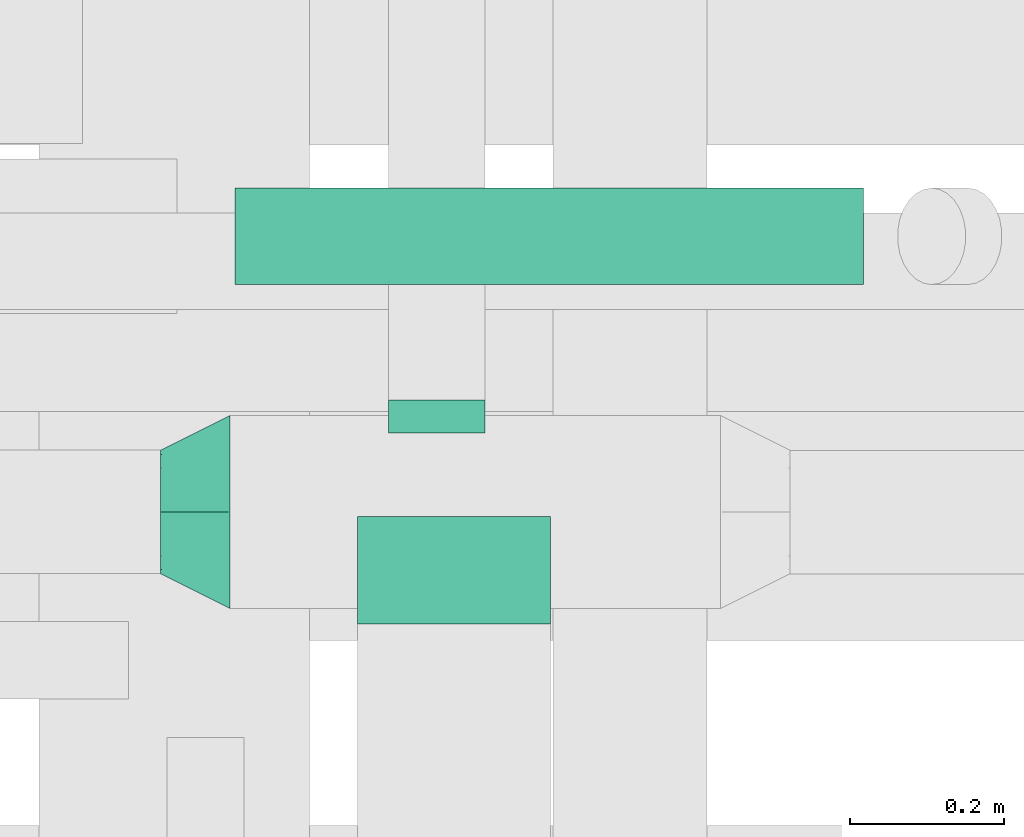
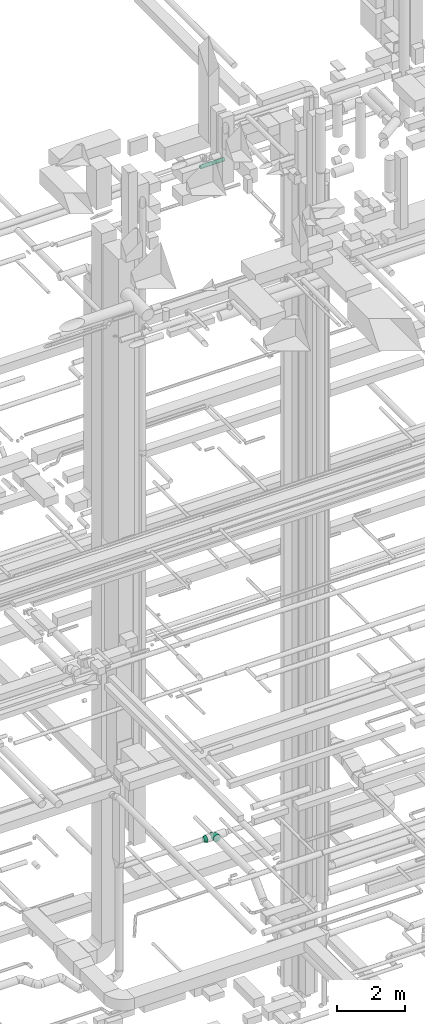
# One storey, part 139 of 337: 3 flow fittings, 1 flow segment.
"""IFC2X3 building model written with IfcOpenShell, lengths in millimetres."""

from ifc_helpers import new_model, entity, si_unit, converted_unit, derived_unit, direction, frame, origin, origin_2d_with_axis, place, context, subcontext, project, spatial, circle, extrude, faceted_brep, source, transform, mapped, material, type_object, type_shapes, element, save


model = new_model("IFC2X3")

# Units and contexts
model_context = context("Model", 3, precision=0.01, world=origin(), true_north=direction((6.12303176911189e-17, 1.0)))
body_context = subcontext(model_context, "Body", "Model", "MODEL_VIEW")
ifc_project = project(units=[si_unit("LENGTHUNIT", "METRE", prefix="MILLI"), si_unit("AREAUNIT", "SQUARE_METRE"), si_unit("VOLUMEUNIT", "CUBIC_METRE"), converted_unit("PLANEANGLEUNIT", "DEGREE", entity("IfcRatioMeasure", 0.0174532925199433), si_unit("PLANEANGLEUNIT", "RADIAN"), dimensions=[0, 0, 0, 0, 0, 0, 0]), si_unit("MASSUNIT", "GRAM", prefix="KILO"), derived_unit("MASSDENSITYUNIT", [(si_unit("MASSUNIT", "GRAM", prefix="KILO"), 1), (si_unit("LENGTHUNIT", "METRE"), -3)]), derived_unit("MOMENTOFINERTIAUNIT", [(si_unit("LENGTHUNIT", "METRE"), 4)]), si_unit("TIMEUNIT", "SECOND"), si_unit("FREQUENCYUNIT", "HERTZ"), si_unit("THERMODYNAMICTEMPERATUREUNIT", "DEGREE_CELSIUS"), derived_unit("THERMALTRANSMITTANCEUNIT", [(si_unit("MASSUNIT", "GRAM", prefix="KILO"), 1), (si_unit("THERMODYNAMICTEMPERATUREUNIT", "KELVIN"), -1), (si_unit("TIMEUNIT", "SECOND"), -3)]), derived_unit("VOLUMETRICFLOWRATEUNIT", [(si_unit("LENGTHUNIT", "METRE"), 3), (si_unit("TIMEUNIT", "SECOND"), -1)]), derived_unit("MASSFLOWRATEUNIT", [(si_unit("MASSUNIT", "GRAM", prefix="KILO"), 1), (si_unit("TIMEUNIT", "SECOND"), -1)]), derived_unit("ROTATIONALFREQUENCYUNIT", [(si_unit("TIMEUNIT", "SECOND"), -1)]), si_unit("ELECTRICCURRENTUNIT", "AMPERE"), si_unit("ELECTRICVOLTAGEUNIT", "VOLT"), si_unit("POWERUNIT", "WATT"), si_unit("FORCEUNIT", "NEWTON", prefix="KILO"), si_unit("ILLUMINANCEUNIT", "LUX"), si_unit("LUMINOUSFLUXUNIT", "LUMEN"), si_unit("LUMINOUSINTENSITYUNIT", "CANDELA"), derived_unit("USERDEFINED", [(si_unit("MASSUNIT", "GRAM", prefix="KILO"), -1), (si_unit("LENGTHUNIT", "METRE"), -2), (si_unit("TIMEUNIT", "SECOND"), 3), (si_unit("LUMINOUSFLUXUNIT", "LUMEN"), 1)]), derived_unit("LINEARVELOCITYUNIT", [(si_unit("LENGTHUNIT", "METRE"), 1), (si_unit("TIMEUNIT", "SECOND"), -1)]), si_unit("PRESSUREUNIT", "PASCAL"), derived_unit("USERDEFINED", [(si_unit("LENGTHUNIT", "METRE"), -2), (si_unit("MASSUNIT", "GRAM", prefix="KILO"), 1), (si_unit("TIMEUNIT", "SECOND"), -2)]), derived_unit("LINEARFORCEUNIT", [(si_unit("MASSUNIT", "GRAM", prefix="KILO"), 1), (si_unit("LENGTHUNIT", "METRE"), 1), (si_unit("TIMEUNIT", "SECOND"), -2), (si_unit("LENGTHUNIT", "METRE"), -1)]), derived_unit("PLANARFORCEUNIT", [(si_unit("MASSUNIT", "GRAM", prefix="KILO"), 1), (si_unit("LENGTHUNIT", "METRE"), 1), (si_unit("TIMEUNIT", "SECOND"), -2), (si_unit("LENGTHUNIT", "METRE"), -2)])], contexts=[model_context])

# Site, building, storey
site_placement = place(None, origin())
site = spatial("IfcSite", under=ifc_project, at=site_placement, CompositionType="ELEMENT")
building_placement = place(site_placement, origin())
building = spatial("IfcBuilding", under=site, at=building_placement, CompositionType="ELEMENT")
storey_placement = place(building_placement, origin())
storey = spatial("IfcBuildingStorey", under=building, at=storey_placement, CompositionType="ELEMENT", Elevation=0.0)

# Flow segment
duct_segment_type = type_object("IfcDuctSegmentType", PredefinedType="NOTDEFINED")
flow_segment_placement = place(storey_placement, frame((29577.42, 15517.89, 27255.9)))
element("IfcFlowSegment", 1, at=flow_segment_placement, inside=storey, type_object=duct_segment_type, context=body_context, shape_type="SweptSolid", body=[
    extrude(circle(Radius=62.5, at=origin_2d_with_axis()), frame((0.0, 64.1, 64.1), z_axis=(1.0, 0.0, 0.0), x_axis=(0.0, -1.0, 0.0)), (0.0, 0.0, 1.0), 814.223471479968),
])

# Flow fittings
ifc_material = material()
duct_fitting_type_1 = type_object("IfcDuctFittingType", PredefinedType="NOTDEFINED", material=ifc_material)
shared_shape_1 = source(origin(), body_context, "Body", "Brep", [
    faceted_brep([(90.0, -73.91, 30.61), (90.0, -76.96, 15.31), (90.0, -80.0, 0.0), (90.0, -76.96, -15.31), (90.0, -73.91, -30.61), (90.0, -65.24, -43.59), (90.0, -56.57, -56.57), (90.0, -43.59, -65.24), (90.0, -30.61, -73.91), (90.0, -15.31, -76.96), (90.0, 0.0, -80.0), (90.0, 15.31, -76.96), (90.0, 30.61, -73.91), (90.0, 43.59, -65.24), (90.0, 56.57, -56.57), (90.0, 65.24, -43.59), (90.0, 73.91, -30.61), (90.0, 76.96, -15.31), (90.0, 80.0, 0.0), (90.0, 76.96, 15.31), (90.0, 73.91, 30.61), (90.0, 65.24, 43.59), (90.0, 56.57, 56.57), (90.0, 43.59, 65.24), (90.0, 30.61, 73.91), (90.0, 15.31, 76.96), (90.0, 0.0, 80.0), (90.0, -15.31, 76.96), (90.0, -30.61, 73.91), (90.0, -43.59, 65.24), (90.0, -56.57, 56.57), (90.0, -65.24, 43.59), (0.0, -125.0, 0.0), (0.0, -118.88, 38.63), (0.0, -101.13, 73.47), (0.0, -73.47, 101.13), (0.0, -38.63, 118.88), (0.0, 0.0, 125.0), (0.0, 38.63, 118.88), (0.0, 73.47, 101.13), (0.0, 101.13, 73.47), (0.0, 118.88, 38.63), (0.0, 125.0, 0.0), (0.0, 118.88, -38.63), (0.0, 101.13, -73.47), (0.0, 73.47, -101.13), (0.0, 38.63, -118.88), (0.0, 0.0, -125.0), (0.0, -38.63, -118.88), (0.0, -73.47, -101.13), (0.0, -101.13, -73.47), (0.0, -118.88, -38.63)], [[[0, 1, 2, 3, 4, 5, 6, 7, 8, 9, 10, 11, 12, 13, 14, 15, 16, 17, 18, 19, 20, 21, 22, 23, 24, 25, 26, 27, 28, 29, 30, 31]], [[32, 33, 34, 35, 36, 37, 38, 39, 40, 41, 42, 43, 44, 45, 46, 47, 48, 49, 50, 51]], [[37, 25, 38]], [[24, 39, 38]], [[40, 22, 21, 20]], [[23, 22, 39, 24]], [[41, 20, 19]], [[18, 42, 19]], [[25, 24, 38]], [[40, 20, 41]], [[19, 42, 41]], [[25, 37, 26]], [[22, 40, 39]], [[32, 1, 33]], [[0, 34, 33]], [[35, 30, 29, 28]], [[31, 30, 34, 0]], [[36, 28, 27]], [[26, 37, 27]], [[1, 0, 33]], [[35, 28, 36]], [[27, 37, 36]], [[1, 32, 2]], [[30, 35, 34]], [[47, 9, 48]], [[8, 49, 48]], [[50, 6, 5, 4]], [[7, 6, 49, 8]], [[51, 4, 3]], [[2, 32, 3]], [[9, 8, 48]], [[50, 4, 51]], [[3, 32, 51]], [[9, 47, 10]], [[6, 50, 49]], [[42, 17, 43]], [[16, 44, 43]], [[45, 14, 13, 12]], [[15, 14, 44, 16]], [[46, 12, 11]], [[10, 47, 11]], [[17, 16, 43]], [[45, 12, 46]], [[11, 47, 46]], [[17, 42, 18]], [[14, 45, 44]]]),
])
type_shapes(duct_fitting_type_1, [shared_shape_1])
flow_fitting_1_placement = place(storey_placement, frame((29571.25, 15224.94, 3600.0), z_axis=(0.0, 0.0, 1.0), x_axis=(-1.0, 0.0, 0.0)))
element("IfcFlowFitting", 2, at=flow_fitting_1_placement, inside=storey, type_object=duct_fitting_type_1, material=ifc_material, context=body_context, shape_type="MappedRepresentation", body=[
    mapped(shared_shape_1, transform((0.0, 0.0, 0.0), scale=1.0)),
])
duct_fitting_type_2 = type_object("IfcDuctFittingType", PredefinedType="NOTDEFINED", material=ifc_material)
shared_shape_2 = source(origin(), body_context, "Body", "Brep", [
    faceted_brep([(20.0, 16.18, -60.37), (20.0, 31.25, -54.13), (20.0, 44.19, -44.19), (20.0, 54.13, -31.25), (20.0, 60.37, -16.18), (20.0, 62.5, 0.0), (20.0, 60.37, 16.18), (20.0, 54.13, 31.25), (20.0, 44.19, 44.19), (20.0, 31.25, 54.13), (20.0, 16.18, 60.37), (20.0, 0.0, 62.5), (20.0, -16.18, 60.37), (20.0, -31.25, 54.13), (20.0, -44.19, 44.19), (20.0, -54.13, 31.25), (20.0, -60.37, 16.18), (20.0, -62.5, 0.0), (20.0, -60.37, -16.18), (20.0, -54.13, -31.25), (20.0, -44.19, -44.19), (20.0, -31.25, -54.13), (20.0, -16.18, -60.37), (20.0, 0.0, -62.5), (0.0, 0.0, 62.5), (0.0, 16.18, 60.37), (-22.84, 16.18, 60.37), (-22.84, 0.0, 62.5), (0.0, 31.25, 54.13), (-22.84, 31.25, 54.13), (0.0, 44.19, 44.19), (-22.84, 44.19, 44.19), (0.0, 54.13, 31.25), (0.0, 60.37, 16.18), (-22.84, 60.37, 16.18), (-22.84, 54.13, 31.25), (0.0, 62.5, 0.0), (-22.84, 62.5, 0.0), (0.0, 60.37, -16.18), (-22.84, 60.37, -16.18), (0.0, 54.13, -31.25), (-22.84, 54.13, -31.25), (0.0, 44.19, -44.19), (-22.84, 44.19, -44.19), (0.0, 31.25, -54.13), (0.0, 16.18, -60.37), (-22.84, 16.18, -60.37), (-22.84, 31.25, -54.13), (0.0, 0.0, -62.5), (-22.84, 0.0, -62.5), (0.0, -16.18, -60.37), (-22.84, -16.18, -60.37), (0.0, -31.25, -54.13), (-22.84, -31.25, -54.13), (0.0, -44.19, -44.19), (-22.84, -44.19, -44.19), (0.0, -54.13, -31.25), (0.0, -60.37, -16.18), (-22.84, -60.37, -16.18), (-22.84, -54.13, -31.25), (0.0, -62.5, 0.0), (-22.84, -62.5, 0.0), (0.0, -60.37, 16.18), (-22.84, -60.37, 16.18), (0.0, -54.13, 31.25), (-22.84, -54.13, 31.25), (0.0, -44.19, 44.19), (-22.84, -44.19, 44.19), (0.0, -31.25, 54.13), (0.0, -16.18, 60.37), (-22.84, -16.18, 60.37), (-22.84, -31.25, 54.13)], [[[0, 1, 2, 3, 4, 5, 6, 7, 8, 9, 10, 11, 12, 13, 14, 15, 16, 17, 18, 19, 20, 21, 22, 23]], [[24, 11, 10, 25, 26, 27]], [[25, 10, 9, 28, 29, 26]], [[28, 9, 8, 30, 31, 29]], [[32, 7, 6, 33, 34, 35]], [[33, 6, 5, 36, 37, 34]], [[30, 8, 7, 32, 35, 31]], [[36, 5, 4, 38, 39, 37]], [[38, 4, 3, 40, 41, 39]], [[40, 3, 2, 42, 43, 41]], [[44, 1, 0, 45, 46, 47]], [[45, 0, 23, 48, 49, 46]], [[42, 2, 1, 44, 47, 43]], [[48, 23, 22, 50, 51, 49]], [[50, 22, 21, 52, 53, 51]], [[52, 21, 20, 54, 55, 53]], [[56, 19, 18, 57, 58, 59]], [[57, 18, 17, 60, 61, 58]], [[54, 20, 19, 56, 59, 55]], [[60, 17, 16, 62, 63, 61]], [[62, 16, 15, 64, 65, 63]], [[64, 15, 14, 66, 67, 65]], [[68, 13, 12, 69, 70, 71]], [[69, 12, 11, 24, 27, 70]], [[66, 14, 13, 68, 71, 67]], [[49, 51, 53, 55, 59, 58, 61, 63, 65, 67, 71, 70, 27, 26, 29, 31, 35, 34, 37, 39, 41, 43, 47, 46]]]),
])
type_shapes(duct_fitting_type_2, [shared_shape_2])
flow_fitting_2_placement = place(storey_placement, frame((29838.75, 15349.94, 3600.0), z_axis=(0.0, 0.0, -1.0), x_axis=(0.0, 1.0, 0.0)))
element("IfcFlowFitting", 3, at=flow_fitting_2_placement, inside=storey, type_object=duct_fitting_type_2, material=ifc_material, context=body_context, shape_type="MappedRepresentation", body=[
    mapped(shared_shape_2, transform((0.0, 0.0, 0.0), scale=1.0)),
])
duct_fitting_type_3 = type_object("IfcDuctFittingType", PredefinedType="NOTDEFINED", material=ifc_material)
shared_shape_3 = source(origin(), body_context, "Body", "Brep", [
    faceted_brep([(20.0, 0.0, -125.0), (20.0, 32.35, -120.74), (20.0, 62.5, -108.25), (20.0, 88.39, -88.39), (20.0, 108.25, -62.5), (20.0, 120.74, -32.35), (20.0, 125.0, 0.0), (20.0, 120.74, 32.35), (20.0, 108.25, 62.5), (20.0, 88.39, 88.39), (20.0, 62.5, 108.25), (20.0, 32.35, 120.74), (20.0, 0.0, 125.0), (20.0, -32.35, 120.74), (20.0, -62.5, 108.25), (20.0, -88.39, 88.39), (20.0, -108.25, 62.5), (20.0, -120.74, 32.35), (20.0, -125.0, 0.0), (20.0, -120.74, -32.35), (20.0, -108.25, -62.5), (20.0, -88.39, -88.39), (20.0, -62.5, -108.25), (20.0, -32.35, -120.74), (0.0, 0.0, 125.0), (-118.9, 0.0, 125.0), (-118.9, -32.35, 120.74), (0.0, -32.35, 120.74), (-118.9, -62.5, 108.25), (0.0, -62.5, 108.25), (0.0, -88.39, 88.39), (-118.9, -88.39, 88.39), (0.0, -108.25, 62.5), (-118.9, -108.25, 62.5), (-118.9, -120.74, 32.35), (0.0, -120.74, 32.35), (-118.9, -125.0, 0.0), (0.0, -125.0, 0.0), (-118.9, -120.74, -32.35), (0.0, -120.74, -32.35), (-118.9, -108.25, -62.5), (0.0, -108.25, -62.5), (0.0, -88.39, -88.39), (-118.9, -88.39, -88.39), (0.0, -62.5, -108.25), (-118.9, -62.5, -108.25), (-118.9, -32.35, -120.74), (0.0, -32.35, -120.74), (-118.9, 0.0, -125.0), (0.0, 0.0, -125.0), (-118.9, 32.35, -120.74), (0.0, 32.35, -120.74), (-118.9, 62.5, -108.25), (0.0, 62.5, -108.25), (0.0, 88.39, -88.39), (-118.9, 88.39, -88.39), (0.0, 108.25, -62.5), (-118.9, 108.25, -62.5), (-118.9, 120.74, -32.35), (0.0, 120.74, -32.35), (-118.9, 125.0, 0.0), (0.0, 125.0, 0.0), (-118.9, 120.74, 32.35), (0.0, 120.74, 32.35), (-118.9, 108.25, 62.5), (0.0, 108.25, 62.5), (0.0, 88.39, 88.39), (-118.9, 88.39, 88.39), (0.0, 62.5, 108.25), (-118.9, 62.5, 108.25), (-118.9, 32.35, 120.74), (0.0, 32.35, 120.74)], [[[0, 1, 2, 3, 4, 5, 6, 7, 8, 9, 10, 11, 12, 13, 14, 15, 16, 17, 18, 19, 20, 21, 22, 23]], [[13, 12, 24, 25, 26, 27]], [[14, 13, 27, 26, 28, 29]], [[30, 15, 14, 29, 28, 31]], [[17, 16, 32, 33, 34, 35]], [[18, 17, 35, 34, 36, 37]], [[32, 16, 15, 30, 31, 33]], [[19, 18, 37, 36, 38, 39]], [[20, 19, 39, 38, 40, 41]], [[42, 21, 20, 41, 40, 43]], [[23, 22, 44, 45, 46, 47]], [[0, 23, 47, 46, 48, 49]], [[44, 22, 21, 42, 43, 45]], [[1, 0, 49, 48, 50, 51]], [[2, 1, 51, 50, 52, 53]], [[54, 3, 2, 53, 52, 55]], [[5, 4, 56, 57, 58, 59]], [[6, 5, 59, 58, 60, 61]], [[56, 4, 3, 54, 55, 57]], [[7, 6, 61, 60, 62, 63]], [[8, 7, 63, 62, 64, 65]], [[66, 9, 8, 65, 64, 67]], [[11, 10, 68, 69, 70, 71]], [[12, 11, 71, 70, 25, 24]], [[68, 10, 9, 66, 67, 69]], [[46, 45, 43, 40, 38, 36, 34, 33, 31, 28, 26, 25, 70, 69, 67, 64, 62, 60, 58, 57, 55, 52, 50, 48]]]),
])
type_shapes(duct_fitting_type_3, [shared_shape_3])
flow_fitting_3_placement = place(storey_placement, frame((29861.25, 15099.94, 3600.0), z_axis=(0.0, 0.0, -1.0), x_axis=(0.0, -1.0, 0.0)))
element("IfcFlowFitting", 4, at=flow_fitting_3_placement, inside=storey, type_object=duct_fitting_type_3, material=ifc_material, context=body_context, shape_type="MappedRepresentation", body=[
    mapped(shared_shape_3, transform((0.0, 0.0, 0.0), scale=1.0)),
])

save(model, "model.ifc")
